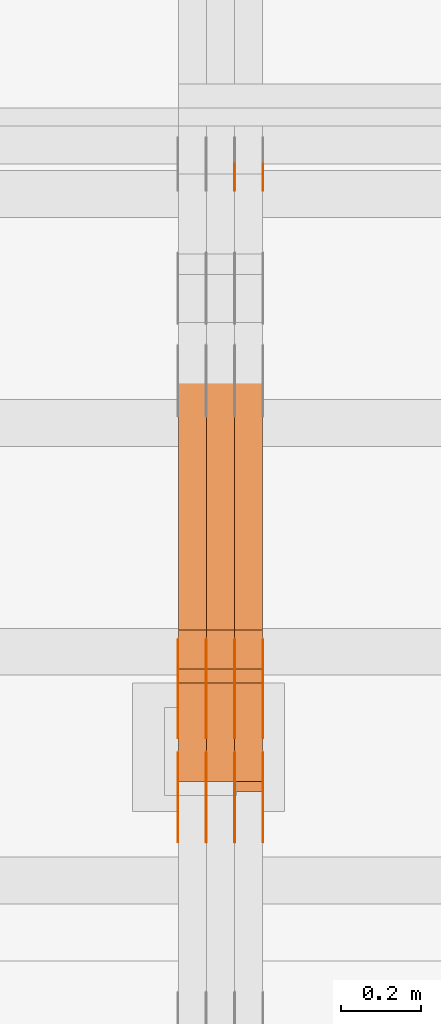
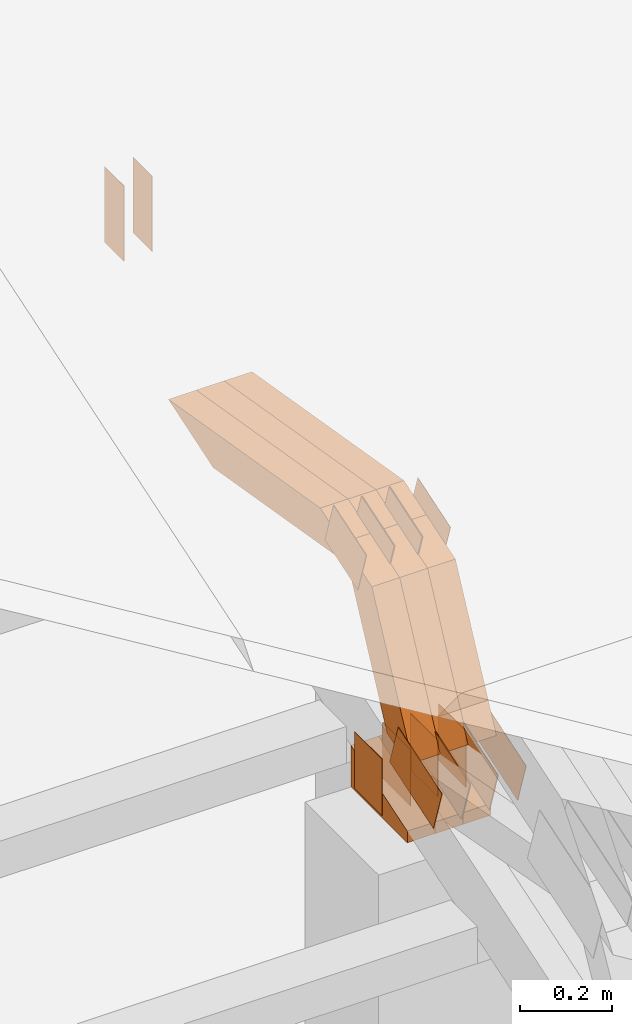
# One storey, part 91 of 385: 29 proxies.
"""IFC2X3 building model written with IfcOpenShell, lengths in millimetres."""

from ifc_helpers import new_model, entity, si_unit, converted_unit, derived_unit, direction, frame, frame_2d, origin, place, context, subcontext, project, spatial, polyline, rectangle, outline, extrude, source, transform, mapped, material, type_object, type_shapes, element, save


model = new_model("IFC2X3")

# Units and contexts
model_context = context("Model", 3, precision=0.01, world=origin(), true_north=direction((6.12303176911189e-17, 1.0)))
body_context = subcontext(model_context, "Body", "Model", "MODEL_VIEW")
ifc_project = project(units=[si_unit("LENGTHUNIT", "METRE", prefix="MILLI"), si_unit("AREAUNIT", "SQUARE_METRE"), si_unit("VOLUMEUNIT", "CUBIC_METRE"), converted_unit("PLANEANGLEUNIT", "DEGREE", entity("IfcRatioMeasure", 0.0174532925199433), si_unit("PLANEANGLEUNIT", "RADIAN"), dimensions=[0, 0, 0, 0, 0, 0, 0]), si_unit("MASSUNIT", "GRAM", prefix="KILO"), derived_unit("MASSDENSITYUNIT", [(si_unit("MASSUNIT", "GRAM", prefix="KILO"), 1), (si_unit("LENGTHUNIT", "METRE"), -3)]), si_unit("TIMEUNIT", "SECOND"), si_unit("FREQUENCYUNIT", "HERTZ"), si_unit("THERMODYNAMICTEMPERATUREUNIT", "DEGREE_CELSIUS"), derived_unit("THERMALTRANSMITTANCEUNIT", [(si_unit("MASSUNIT", "GRAM", prefix="KILO"), 1), (si_unit("THERMODYNAMICTEMPERATUREUNIT", "KELVIN"), -1), (si_unit("TIMEUNIT", "SECOND"), -3)]), derived_unit("VOLUMETRICFLOWRATEUNIT", [(si_unit("LENGTHUNIT", "METRE"), 3), (si_unit("TIMEUNIT", "SECOND"), -1)]), si_unit("ELECTRICCURRENTUNIT", "AMPERE"), si_unit("ELECTRICVOLTAGEUNIT", "VOLT"), si_unit("POWERUNIT", "WATT"), si_unit("FORCEUNIT", "NEWTON", prefix="KILO"), si_unit("ILLUMINANCEUNIT", "LUX"), si_unit("LUMINOUSFLUXUNIT", "LUMEN"), si_unit("LUMINOUSINTENSITYUNIT", "CANDELA"), derived_unit("USERDEFINED", [(si_unit("MASSUNIT", "GRAM", prefix="KILO"), -1), (si_unit("LENGTHUNIT", "METRE"), -2), (si_unit("TIMEUNIT", "SECOND"), 3), (si_unit("LUMINOUSFLUXUNIT", "LUMEN"), 1)]), derived_unit("LINEARVELOCITYUNIT", [(si_unit("LENGTHUNIT", "METRE"), 1), (si_unit("TIMEUNIT", "SECOND"), -1)]), si_unit("PRESSUREUNIT", "PASCAL"), derived_unit("USERDEFINED", [(si_unit("LENGTHUNIT", "METRE"), -2), (si_unit("MASSUNIT", "GRAM", prefix="KILO"), 1), (si_unit("TIMEUNIT", "SECOND"), -2)])], contexts=[model_context])

# Site, building, storey
site_placement = place(None, origin())
site = spatial("IfcSite", under=ifc_project, at=site_placement, CompositionType="ELEMENT")
building_placement = place(site_placement, origin())
building = spatial("IfcBuilding", under=site, at=building_placement, CompositionType="ELEMENT")
storey_placement = place(building_placement, origin())
storey = spatial("IfcBuildingStorey", under=building, at=storey_placement, Name="Default", CompositionType="ELEMENT", Elevation=0.0)

# Proxies
ifc_material_1 = material(Name="IfcSurfaceStyle #140276")
building_element_proxy_type_1 = type_object("IfcBuildingElementProxyType", PredefinedType="NOTDEFINED", material=ifc_material_1)
shared_shape_1 = source(origin(), body_context, "Body", "SweptSolid", [
    extrude(rectangle(XDim=200.0, YDim=84.0, at=frame_2d((0.0, -7.105427357601e-15), x_axis=(1.0, 0.0))), frame((100.0, 42.0, 0.0), z_axis=(0.0, 0.0, 1.0), x_axis=(-1.0, 0.0, 0.0)), (0.0, 0.0, 1.0), 1.3),
])
type_shapes(building_element_proxy_type_1, [shared_shape_1])
proxy_1_placement = place(building_placement, frame((9386.29999999998, 13702.0, 3651.4150390625), z_axis=(-1.0, 0.0, 0.0), x_axis=(0.0, 0.0, -1.0)))
element("IfcBuildingElementProxy", 1, at=proxy_1_placement, inside=storey, type_object=building_element_proxy_type_1, material=ifc_material_1, context=body_context, shape_type="MappedRepresentation", body=[
    mapped(shared_shape_1, transform((0.0, 0.0, 0.0), scale=1.0)),
])
ifc_material_2 = material(Name="IfcSurfaceStyle #140219")
building_element_proxy_type_2 = type_object("IfcBuildingElementProxyType", PredefinedType="NOTDEFINED", material=ifc_material_2)
shared_shape_2 = source(origin(), body_context, "Body", "SweptSolid", [
    extrude(rectangle(XDim=200.0, YDim=84.0, at=frame_2d((0.0, -7.105427357601e-15), x_axis=(1.0, 0.0))), frame((100.0, 42.0, 0.0), z_axis=(0.0, 0.0, 1.0), x_axis=(-1.0, 0.0, 0.0)), (0.0, 0.0, 1.0), 1.3),
])
type_shapes(building_element_proxy_type_2, [shared_shape_2])
proxy_2_placement = place(building_placement, frame((9315.0, 13702.0, 3651.4150390625), z_axis=(-1.0, 0.0, 0.0), x_axis=(0.0, 0.0, -1.0)))
element("IfcBuildingElementProxy", 2, at=proxy_2_placement, inside=storey, type_object=building_element_proxy_type_2, material=ifc_material_2, context=body_context, shape_type="MappedRepresentation", body=[
    mapped(shared_shape_2, transform((0.0, 0.0, 0.0), scale=1.0)),
])
ifc_material_3 = material(Name="IfcSurfaceStyle #138224")
building_element_proxy_type_3 = type_object("IfcBuildingElementProxyType", PredefinedType="NOTDEFINED", material=ifc_material_3)
shared_shape_3 = source(origin(), body_context, "Body", "SweptSolid", [
    extrude(outline(polyline([(-99.9997874178038, -60.0000528641967), (99.9998102700997, -60.0000528641967), (99.9998251396068, 60.0000528641967), (-99.9998479919027, 60.0000528641967), (-99.9997874178038, -60.0000528641967)])), frame((99.9999918898597, 60.0000528641967, 0.0), z_axis=(0.0, 0.0, 1.0), x_axis=(-1.0, 0.0, 0.0)), (0.0, 0.0, 1.0), 1.3),
])
type_shapes(building_element_proxy_type_3, [shared_shape_3])
proxy_3_placement = place(building_placement, frame((9386.29999999998, 11991.9568177725, 3072.52282247925), z_axis=(-1.0, 0.0, 0.0), x_axis=(0.0, 0.951056516295124, 0.309016994375039)))
element("IfcBuildingElementProxy", 3, at=proxy_3_placement, inside=storey, type_object=building_element_proxy_type_3, material=ifc_material_3, context=body_context, shape_type="MappedRepresentation", body=[
    mapped(shared_shape_3, transform((0.0, 0.0, 0.0), scale=1.0)),
])
ifc_material_4 = material(Name="IfcSurfaceStyle #138167")
building_element_proxy_type_4 = type_object("IfcBuildingElementProxyType", PredefinedType="NOTDEFINED", material=ifc_material_4)
shared_shape_4 = source(origin(), body_context, "Body", "SweptSolid", [
    extrude(outline(polyline([(-99.9997874178038, -60.0000528641967), (99.9998102700997, -60.0000528641967), (99.9998251396068, 60.0000528641967), (-99.9998479919027, 60.0000528641967), (-99.9997874178038, -60.0000528641967)])), frame((99.9999918898597, 60.0000528641967, 0.0), z_axis=(0.0, 0.0, 1.0), x_axis=(-1.0, 0.0, 0.0)), (0.0, 0.0, 1.0), 1.3),
])
type_shapes(building_element_proxy_type_4, [shared_shape_4])
proxy_4_placement = place(building_placement, frame((9315.0, 11991.9568177725, 3072.52282247925), z_axis=(-1.0, 0.0, 0.0), x_axis=(0.0, 0.951056516295124, 0.309016994375039)))
element("IfcBuildingElementProxy", 4, at=proxy_4_placement, inside=storey, type_object=building_element_proxy_type_4, material=ifc_material_4, context=body_context, shape_type="MappedRepresentation", body=[
    mapped(shared_shape_4, transform((0.0, 0.0, 0.0), scale=1.0)),
])
ifc_material_5 = material(Name="IfcSurfaceStyle #138110")
building_element_proxy_type_5 = type_object("IfcBuildingElementProxyType", PredefinedType="NOTDEFINED", material=ifc_material_5)
shared_shape_5 = source(origin(), body_context, "Body", "SweptSolid", [
    extrude(outline(polyline([(-99.9997874178038, -60.0000528641967), (99.9998102700997, -60.0000528641967), (99.9998251396068, 60.0000528641967), (-99.9998479919027, 60.0000528641967), (-99.9997874178038, -60.0000528641967)])), frame((99.9999918898597, 60.0000528641967, 0.0), z_axis=(0.0, 0.0, 1.0), x_axis=(-1.0, 0.0, 0.0)), (0.0, 0.0, 1.0), 1.3),
])
type_shapes(building_element_proxy_type_5, [shared_shape_5])
proxy_5_placement = place(building_placement, frame((9316.29999999998, 11991.9568177725, 3072.52282247925), z_axis=(-1.0, 0.0, 0.0), x_axis=(0.0, 0.951056516295124, 0.309016994375039)))
element("IfcBuildingElementProxy", 5, at=proxy_5_placement, inside=storey, type_object=building_element_proxy_type_5, material=ifc_material_5, context=body_context, shape_type="MappedRepresentation", body=[
    mapped(shared_shape_5, transform((0.0, 0.0, 0.0), scale=1.0)),
])
ifc_material_6 = material(Name="IfcSurfaceStyle #138053")
building_element_proxy_type_6 = type_object("IfcBuildingElementProxyType", PredefinedType="NOTDEFINED", material=ifc_material_6)
shared_shape_6 = source(origin(), body_context, "Body", "SweptSolid", [
    extrude(outline(polyline([(-99.9997874178038, -60.0000528641967), (99.9998102700997, -60.0000528641967), (99.9998251396068, 60.0000528641967), (-99.9998479919027, 60.0000528641967), (-99.9997874178038, -60.0000528641967)])), frame((99.9999918898597, 60.0000528641967, 0.0), z_axis=(0.0, 0.0, 1.0), x_axis=(-1.0, 0.0, 0.0)), (0.0, 0.0, 1.0), 1.29999999999998),
])
type_shapes(building_element_proxy_type_6, [shared_shape_6])
proxy_6_placement = place(building_placement, frame((9245.0, 11991.9568177725, 3072.52282247925), z_axis=(-1.0, 0.0, 0.0), x_axis=(0.0, 0.951056516295124, 0.309016994375039)))
element("IfcBuildingElementProxy", 6, at=proxy_6_placement, inside=storey, type_object=building_element_proxy_type_6, material=ifc_material_6, context=body_context, shape_type="MappedRepresentation", body=[
    mapped(shared_shape_6, transform((0.0, 0.0, 0.0), scale=1.0)),
])
ifc_material_7 = material(Name="IfcSurfaceStyle #137996")
building_element_proxy_type_7 = type_object("IfcBuildingElementProxyType", PredefinedType="NOTDEFINED", material=ifc_material_7)
shared_shape_7 = source(origin(), body_context, "Body", "SweptSolid", [
    extrude(outline(polyline([(-99.9997874178038, -60.0000528641967), (99.9998102700997, -60.0000528641967), (99.9998251396068, 60.0000528641967), (-99.9998479919027, 60.0000528641967), (-99.9997874178038, -60.0000528641967)])), frame((99.9999918898597, 60.0000528641967, 0.0), z_axis=(0.0, 0.0, 1.0), x_axis=(-1.0, 0.0, 0.0)), (0.0, 0.0, 1.0), 1.29999999999998),
])
type_shapes(building_element_proxy_type_7, [shared_shape_7])
proxy_7_placement = place(building_placement, frame((9246.29999999998, 11991.9568177725, 3072.52282247925), z_axis=(-1.0, 0.0, 0.0), x_axis=(0.0, 0.951056516295124, 0.309016994375039)))
element("IfcBuildingElementProxy", 7, at=proxy_7_placement, inside=storey, type_object=building_element_proxy_type_7, material=ifc_material_7, context=body_context, shape_type="MappedRepresentation", body=[
    mapped(shared_shape_7, transform((0.0, 0.0, 0.0), scale=1.0)),
])
ifc_material_8 = material(Name="IfcSurfaceStyle #137939")
building_element_proxy_type_8 = type_object("IfcBuildingElementProxyType", PredefinedType="NOTDEFINED", material=ifc_material_8)
shared_shape_8 = source(origin(), body_context, "Body", "SweptSolid", [
    extrude(outline(polyline([(-99.9997874178038, -60.0000528641967), (99.9998102700997, -60.0000528641967), (99.9998251396068, 60.0000528641967), (-99.9998479919027, 60.0000528641967), (-99.9997874178038, -60.0000528641967)])), frame((99.9999918898597, 60.0000528641967, 0.0), z_axis=(0.0, 0.0, 1.0), x_axis=(-1.0, 0.0, 0.0)), (0.0, 0.0, 1.0), 1.29999999999999),
])
type_shapes(building_element_proxy_type_8, [shared_shape_8])
proxy_8_placement = place(building_placement, frame((9175.0, 11991.9568177725, 3072.52282247925), z_axis=(-1.0, 0.0, 0.0), x_axis=(0.0, 0.951056516295124, 0.309016994375039)))
element("IfcBuildingElementProxy", 8, at=proxy_8_placement, inside=storey, type_object=building_element_proxy_type_8, material=ifc_material_8, context=body_context, shape_type="MappedRepresentation", body=[
    mapped(shared_shape_8, transform((0.0, 0.0, 0.0), scale=1.0)),
])
ifc_material_9 = material(Name="IfcSurfaceStyle #137882")
building_element_proxy_type_9 = type_object("IfcBuildingElementProxyType", PredefinedType="NOTDEFINED", material=ifc_material_9)
shared_shape_9 = source(origin(), body_context, "Body", "SweptSolid", [
    extrude(rectangle(XDim=150.0, YDim=119.999999999985, at=frame_2d((-7.105427357601e-15, 0.0), x_axis=(1.0, 0.0))), frame((75.0, 60.0, 0.0), z_axis=(0.0, 0.0, 1.0), x_axis=(-1.0, 0.0, 0.0)), (0.0, 0.0, 1.0), 1.3),
])
type_shapes(building_element_proxy_type_9, [shared_shape_9])
proxy_9_placement = place(building_placement, frame((9386.29999999998, 12372.95703125, 3007.04687500001), z_axis=(-1.0, 0.0, 0.0), x_axis=(0.0, 0.0, -1.0)))
element("IfcBuildingElementProxy", 9, at=proxy_9_placement, inside=storey, type_object=building_element_proxy_type_9, material=ifc_material_9, context=body_context, shape_type="MappedRepresentation", body=[
    mapped(shared_shape_9, transform((0.0, 0.0, 0.0), scale=1.0)),
])
ifc_material_10 = material(Name="IfcSurfaceStyle #137825")
building_element_proxy_type_10 = type_object("IfcBuildingElementProxyType", PredefinedType="NOTDEFINED", material=ifc_material_10)
shared_shape_10 = source(origin(), body_context, "Body", "SweptSolid", [
    extrude(rectangle(XDim=150.0, YDim=119.999999999985, at=frame_2d((-7.105427357601e-15, 0.0), x_axis=(1.0, 0.0))), frame((75.0, 60.0, 0.0), z_axis=(0.0, 0.0, 1.0), x_axis=(-1.0, 0.0, 0.0)), (0.0, 0.0, 1.0), 1.3),
])
type_shapes(building_element_proxy_type_10, [shared_shape_10])
proxy_10_placement = place(building_placement, frame((9315.0, 12372.95703125, 3007.04687500001), z_axis=(-1.0, 0.0, 0.0), x_axis=(0.0, 0.0, -1.0)))
element("IfcBuildingElementProxy", 10, at=proxy_10_placement, inside=storey, type_object=building_element_proxy_type_10, material=ifc_material_10, context=body_context, shape_type="MappedRepresentation", body=[
    mapped(shared_shape_10, transform((0.0, 0.0, 0.0), scale=1.0)),
])
ifc_material_11 = material(Name="IfcSurfaceStyle #137768")
building_element_proxy_type_11 = type_object("IfcBuildingElementProxyType", PredefinedType="NOTDEFINED", material=ifc_material_11)
shared_shape_11 = source(origin(), body_context, "Body", "SweptSolid", [
    extrude(rectangle(XDim=150.0, YDim=119.999999999985, at=frame_2d((-7.105427357601e-15, 0.0), x_axis=(1.0, 0.0))), frame((75.0, 60.0, 0.0), z_axis=(0.0, 0.0, 1.0), x_axis=(-1.0, 0.0, 0.0)), (0.0, 0.0, 1.0), 1.3),
])
type_shapes(building_element_proxy_type_11, [shared_shape_11])
proxy_11_placement = place(building_placement, frame((9316.29999999998, 12372.95703125, 3007.04687500001), z_axis=(-1.0, 0.0, 0.0), x_axis=(0.0, 0.0, -1.0)))
element("IfcBuildingElementProxy", 11, at=proxy_11_placement, inside=storey, type_object=building_element_proxy_type_11, material=ifc_material_11, context=body_context, shape_type="MappedRepresentation", body=[
    mapped(shared_shape_11, transform((0.0, 0.0, 0.0), scale=1.0)),
])
ifc_material_12 = material(Name="IfcSurfaceStyle #137711")
building_element_proxy_type_12 = type_object("IfcBuildingElementProxyType", PredefinedType="NOTDEFINED", material=ifc_material_12)
shared_shape_12 = source(origin(), body_context, "Body", "SweptSolid", [
    extrude(rectangle(XDim=150.0, YDim=119.999999999985, at=frame_2d((-7.105427357601e-15, 0.0), x_axis=(1.0, 0.0))), frame((75.0, 60.0, 0.0), z_axis=(0.0, 0.0, 1.0), x_axis=(-1.0, 0.0, 0.0)), (0.0, 0.0, 1.0), 1.29999999999999),
])
type_shapes(building_element_proxy_type_12, [shared_shape_12])
proxy_12_placement = place(building_placement, frame((9245.0, 12372.95703125, 3007.04687500001), z_axis=(-1.0, 0.0, 0.0), x_axis=(0.0, 0.0, -1.0)))
element("IfcBuildingElementProxy", 12, at=proxy_12_placement, inside=storey, type_object=building_element_proxy_type_12, material=ifc_material_12, context=body_context, shape_type="MappedRepresentation", body=[
    mapped(shared_shape_12, transform((0.0, 0.0, 0.0), scale=1.0)),
])
ifc_material_13 = material(Name="IfcSurfaceStyle #137654")
building_element_proxy_type_13 = type_object("IfcBuildingElementProxyType", PredefinedType="NOTDEFINED", material=ifc_material_13)
shared_shape_13 = source(origin(), body_context, "Body", "SweptSolid", [
    extrude(rectangle(XDim=150.0, YDim=119.999999999985, at=frame_2d((-7.105427357601e-15, 0.0), x_axis=(1.0, 0.0))), frame((75.0, 60.0, 0.0), z_axis=(0.0, 0.0, 1.0), x_axis=(-1.0, 0.0, 0.0)), (0.0, 0.0, 1.0), 1.29999999999999),
])
type_shapes(building_element_proxy_type_13, [shared_shape_13])
proxy_13_placement = place(building_placement, frame((9246.29999999998, 12372.95703125, 3007.04687500001), z_axis=(-1.0, 0.0, 0.0), x_axis=(0.0, 0.0, -1.0)))
element("IfcBuildingElementProxy", 13, at=proxy_13_placement, inside=storey, type_object=building_element_proxy_type_13, material=ifc_material_13, context=body_context, shape_type="MappedRepresentation", body=[
    mapped(shared_shape_13, transform((0.0, 0.0, 0.0), scale=1.0)),
])
ifc_material_14 = material(Name="IfcSurfaceStyle #137597")
building_element_proxy_type_14 = type_object("IfcBuildingElementProxyType", PredefinedType="NOTDEFINED", material=ifc_material_14)
shared_shape_14 = source(origin(), body_context, "Body", "SweptSolid", [
    extrude(rectangle(XDim=150.0, YDim=119.999999999985, at=frame_2d((-7.105427357601e-15, 0.0), x_axis=(1.0, 0.0))), frame((75.0, 60.0, 0.0), z_axis=(0.0, 0.0, 1.0), x_axis=(-1.0, 0.0, 0.0)), (0.0, 0.0, 1.0), 1.29999999999999),
])
type_shapes(building_element_proxy_type_14, [shared_shape_14])
proxy_14_placement = place(building_placement, frame((9175.0, 12372.95703125, 3007.04687500001), z_axis=(-1.0, 0.0, 0.0), x_axis=(0.0, 0.0, -1.0)))
element("IfcBuildingElementProxy", 14, at=proxy_14_placement, inside=storey, type_object=building_element_proxy_type_14, material=ifc_material_14, context=body_context, shape_type="MappedRepresentation", body=[
    mapped(shared_shape_14, transform((0.0, 0.0, 0.0), scale=1.0)),
])
ifc_material_15 = material(Name="IfcSurfaceStyle #130700")
building_element_proxy_type_15 = type_object("IfcBuildingElementProxyType", PredefinedType="NOTDEFINED", material=ifc_material_15)
shared_shape_15 = source(origin(), body_context, "Body", "SweptSolid", [
    extrude(outline(polyline([(-74.9998754286244, -60.0000016373506), (74.9998605591063, -60.0000016373506), (74.9998754286244, 60.0000016373506), (-74.9998605591063, 60.0000016373506), (-74.9998754286244, -60.0000016373506)])), frame((74.9998754286244, 60.0000016373506, 0.0), z_axis=(0.0, 0.0, 1.0), x_axis=(-1.0, 0.0, 0.0)), (0.0, 0.0, 1.0), 1.3),
])
type_shapes(building_element_proxy_type_15, [shared_shape_15])
proxy_15_placement = place(building_placement, frame((9386.29999999998, 12321.1620861463, 3506.17707344366), z_axis=(-1.0, 0.0, 0.0), x_axis=(0.0, 0.951056516295154, 0.309016994374948)))
element("IfcBuildingElementProxy", 15, at=proxy_15_placement, inside=storey, type_object=building_element_proxy_type_15, material=ifc_material_15, context=body_context, shape_type="MappedRepresentation", body=[
    mapped(shared_shape_15, transform((0.0, 0.0, 0.0), scale=1.0)),
])
ifc_material_16 = material(Name="IfcSurfaceStyle #130643")
building_element_proxy_type_16 = type_object("IfcBuildingElementProxyType", PredefinedType="NOTDEFINED", material=ifc_material_16)
shared_shape_16 = source(origin(), body_context, "Body", "SweptSolid", [
    extrude(outline(polyline([(-74.9998754286244, -60.0000016373506), (74.9998605591063, -60.0000016373506), (74.9998754286244, 60.0000016373506), (-74.9998605591063, 60.0000016373506), (-74.9998754286244, -60.0000016373506)])), frame((74.9998754286244, 60.0000016373506, 0.0), z_axis=(0.0, 0.0, 1.0), x_axis=(-1.0, 0.0, 0.0)), (0.0, 0.0, 1.0), 1.3),
])
type_shapes(building_element_proxy_type_16, [shared_shape_16])
proxy_16_placement = place(building_placement, frame((9315.0, 12321.1620861463, 3506.17707344366), z_axis=(-1.0, 0.0, 0.0), x_axis=(0.0, 0.951056516295154, 0.309016994374948)))
element("IfcBuildingElementProxy", 16, at=proxy_16_placement, inside=storey, type_object=building_element_proxy_type_16, material=ifc_material_16, context=body_context, shape_type="MappedRepresentation", body=[
    mapped(shared_shape_16, transform((0.0, 0.0, 0.0), scale=1.0)),
])
ifc_material_17 = material(Name="IfcSurfaceStyle #130586")
building_element_proxy_type_17 = type_object("IfcBuildingElementProxyType", PredefinedType="NOTDEFINED", material=ifc_material_17)
shared_shape_17 = source(origin(), body_context, "Body", "SweptSolid", [
    extrude(outline(polyline([(-74.9998754286244, -60.0000016373506), (74.9998605591063, -60.0000016373506), (74.9998754286244, 60.0000016373506), (-74.9998605591063, 60.0000016373506), (-74.9998754286244, -60.0000016373506)])), frame((74.9998754286244, 60.0000016373506, 0.0), z_axis=(0.0, 0.0, 1.0), x_axis=(-1.0, 0.0, 0.0)), (0.0, 0.0, 1.0), 1.3),
])
type_shapes(building_element_proxy_type_17, [shared_shape_17])
proxy_17_placement = place(building_placement, frame((9316.29999999998, 12321.1620861463, 3506.17707344366), z_axis=(-1.0, 0.0, 0.0), x_axis=(0.0, 0.951056516295154, 0.309016994374948)))
element("IfcBuildingElementProxy", 17, at=proxy_17_placement, inside=storey, type_object=building_element_proxy_type_17, material=ifc_material_17, context=body_context, shape_type="MappedRepresentation", body=[
    mapped(shared_shape_17, transform((0.0, 0.0, 0.0), scale=1.0)),
])
ifc_material_18 = material(Name="IfcSurfaceStyle #130529")
building_element_proxy_type_18 = type_object("IfcBuildingElementProxyType", PredefinedType="NOTDEFINED", material=ifc_material_18)
shared_shape_18 = source(origin(), body_context, "Body", "SweptSolid", [
    extrude(outline(polyline([(-74.9998754286244, -60.0000016373506), (74.9998605591063, -60.0000016373506), (74.9998754286244, 60.0000016373506), (-74.9998605591063, 60.0000016373506), (-74.9998754286244, -60.0000016373506)])), frame((74.9998754286244, 60.0000016373506, 0.0), z_axis=(0.0, 0.0, 1.0), x_axis=(-1.0, 0.0, 0.0)), (0.0, 0.0, 1.0), 1.29999999999999),
])
type_shapes(building_element_proxy_type_18, [shared_shape_18])
proxy_18_placement = place(building_placement, frame((9245.0, 12321.1620861463, 3506.17707344366), z_axis=(-1.0, 0.0, 0.0), x_axis=(0.0, 0.951056516295154, 0.309016994374948)))
element("IfcBuildingElementProxy", 18, at=proxy_18_placement, inside=storey, type_object=building_element_proxy_type_18, material=ifc_material_18, context=body_context, shape_type="MappedRepresentation", body=[
    mapped(shared_shape_18, transform((0.0, 0.0, 0.0), scale=1.0)),
])
ifc_material_19 = material(Name="IfcSurfaceStyle #130472")
building_element_proxy_type_19 = type_object("IfcBuildingElementProxyType", PredefinedType="NOTDEFINED", material=ifc_material_19)
shared_shape_19 = source(origin(), body_context, "Body", "SweptSolid", [
    extrude(outline(polyline([(-74.9998754286244, -60.0000016373506), (74.9998605591063, -60.0000016373506), (74.9998754286244, 60.0000016373506), (-74.9998605591063, 60.0000016373506), (-74.9998754286244, -60.0000016373506)])), frame((74.9998754286244, 60.0000016373506, 0.0), z_axis=(0.0, 0.0, 1.0), x_axis=(-1.0, 0.0, 0.0)), (0.0, 0.0, 1.0), 1.29999999999999),
])
type_shapes(building_element_proxy_type_19, [shared_shape_19])
proxy_19_placement = place(building_placement, frame((9246.29999999998, 12321.1620861463, 3506.17707344366), z_axis=(-1.0, 0.0, 0.0), x_axis=(0.0, 0.951056516295154, 0.309016994374948)))
element("IfcBuildingElementProxy", 19, at=proxy_19_placement, inside=storey, type_object=building_element_proxy_type_19, material=ifc_material_19, context=body_context, shape_type="MappedRepresentation", body=[
    mapped(shared_shape_19, transform((0.0, 0.0, 0.0), scale=1.0)),
])
ifc_material_20 = material(Name="IfcSurfaceStyle #130415")
building_element_proxy_type_20 = type_object("IfcBuildingElementProxyType", PredefinedType="NOTDEFINED", material=ifc_material_20)
shared_shape_20 = source(origin(), body_context, "Body", "SweptSolid", [
    extrude(outline(polyline([(-74.9998754286244, -60.0000016373506), (74.9998605591063, -60.0000016373506), (74.9998754286244, 60.0000016373506), (-74.9998605591063, 60.0000016373506), (-74.9998754286244, -60.0000016373506)])), frame((74.9998754286244, 60.0000016373506, 0.0), z_axis=(0.0, 0.0, 1.0), x_axis=(-1.0, 0.0, 0.0)), (0.0, 0.0, 1.0), 1.29999999999999),
])
type_shapes(building_element_proxy_type_20, [shared_shape_20])
proxy_20_placement = place(building_placement, frame((9175.0, 12321.1620861463, 3506.17707344366), z_axis=(-1.0, 0.0, 0.0), x_axis=(0.0, 0.951056516295154, 0.309016994374948)))
element("IfcBuildingElementProxy", 20, at=proxy_20_placement, inside=storey, type_object=building_element_proxy_type_20, material=ifc_material_20, context=body_context, shape_type="MappedRepresentation", body=[
    mapped(shared_shape_20, transform((0.0, 0.0, 0.0), scale=1.0)),
])
ifc_material_21 = material(Name="IfcSurfaceStyle #122240")
building_element_proxy_type_21 = type_object("IfcBuildingElementProxyType", Name="T1-E1 122238", PredefinedType="NOTDEFINED", material=ifc_material_21)
shared_shape_21 = source(origin(), body_context, "Body", "SweptSolid", [
    extrude(outline(polyline([(-75.1378173828004, -122.500000000005), (35.3350830078246, -122.500000000005), (35.3350830078004, 122.500000000005), (4.46765136717545, 122.500000000005), (-75.1378173828004, -122.500000000005)])), frame((35.3350830078246, 122.500000104877, 0.0), z_axis=(0.0, 0.0, 1.0), x_axis=(-1.0, 0.0, 0.0)), (0.0, 0.0, 1.0), 70.0),
])
type_shapes(building_element_proxy_type_21, [shared_shape_21])
proxy_21_placement = place(building_placement, frame((9385.0, 12145.0, 2849.54565429685), z_axis=(-1.0, 0.0, 0.0), x_axis=(0.0, 0.0, 1.0)))
element("IfcBuildingElementProxy", 21, at=proxy_21_placement, inside=storey, type_object=building_element_proxy_type_21, material=ifc_material_21, Name="T1-E1", context=body_context, shape_type="MappedRepresentation", body=[
    mapped(shared_shape_21, transform((0.0, 0.0, 0.0), scale=1.0)),
])
ifc_material_22 = material(Name="IfcSurfaceStyle #122183")
building_element_proxy_type_22 = type_object("IfcBuildingElementProxyType", Name="T1-E1 122181", PredefinedType="NOTDEFINED", material=ifc_material_22)
shared_shape_22 = source(origin(), body_context, "Body", "SweptSolid", [
    extrude(outline(polyline([(-75.1378173828004, -122.500000000005), (35.3350830078246, -122.500000000005), (35.3350830078004, 122.500000000005), (4.46765136717545, 122.500000000005), (-75.1378173828004, -122.500000000005)])), frame((35.3350830078246, 122.500000104877, 0.0), z_axis=(0.0, 0.0, 1.0), x_axis=(-1.0, 0.0, 0.0)), (0.0, 0.0, 1.0), 70.0),
])
type_shapes(building_element_proxy_type_22, [shared_shape_22])
proxy_22_placement = place(building_placement, frame((9315.0, 12145.0, 2849.54565429685), z_axis=(-1.0, 0.0, 0.0), x_axis=(0.0, 0.0, 1.0)))
element("IfcBuildingElementProxy", 22, at=proxy_22_placement, inside=storey, type_object=building_element_proxy_type_22, material=ifc_material_22, Name="T1-E1", context=body_context, shape_type="MappedRepresentation", body=[
    mapped(shared_shape_22, transform((0.0, 0.0, 0.0), scale=1.0)),
])
ifc_material_23 = material(Name="IfcSurfaceStyle #122126")
building_element_proxy_type_23 = type_object("IfcBuildingElementProxyType", Name="T1-E1 122124", PredefinedType="NOTDEFINED", material=ifc_material_23)
shared_shape_23 = source(origin(), body_context, "Body", "SweptSolid", [
    extrude(outline(polyline([(-75.1378173828004, -122.500000000005), (35.3350830078246, -122.500000000005), (35.3350830078004, 122.500000000005), (4.46765136717545, 122.500000000005), (-75.1378173828004, -122.500000000005)])), frame((35.3350830078246, 122.500000104877, 0.0), z_axis=(0.0, 0.0, 1.0), x_axis=(-1.0, 0.0, 0.0)), (0.0, 0.0, 1.0), 70.0),
])
type_shapes(building_element_proxy_type_23, [shared_shape_23])
proxy_23_placement = place(building_placement, frame((9245.0, 12145.0, 2849.54565429685), z_axis=(-1.0, 0.0, 0.0), x_axis=(0.0, 0.0, 1.0)))
element("IfcBuildingElementProxy", 23, at=proxy_23_placement, inside=storey, type_object=building_element_proxy_type_23, material=ifc_material_23, Name="T1-E1", context=body_context, shape_type="MappedRepresentation", body=[
    mapped(shared_shape_23, transform((0.0, 0.0, 0.0), scale=1.0)),
])
ifc_material_24 = material(Name="IfcSurfaceStyle #120512")
building_element_proxy_type_24 = type_object("IfcBuildingElementProxyType", Name="T1-W7 120510", PredefinedType="NOTDEFINED", material=ifc_material_24)
shared_shape_24 = source(origin(), body_context, "Body", "SweptSolid", [
    extrude(outline(polyline([(-296.174043820986, -47.5000676566704), (297.841254477443, -47.5000676566704), (283.518570346415, -7.10254316533821e-06), (192.674144473719, 47.500071207942), (-477.859925476591, 47.500071207942), (-296.174043820986, -47.5000676566704)])), frame((297.841254477443, 47.5000816097442, 0.0), z_axis=(0.0, 0.0, 1.0), x_axis=(-1.0, 0.0, 0.0)), (0.0, 0.0, 1.0), 70.0),
])
type_shapes(building_element_proxy_type_24, [shared_shape_24])
proxy_24_placement = place(building_placement, frame((9385.0, 12419.2991208897, 3526.2136755972), z_axis=(-1.0, 0.0, 0.0), x_axis=(0.0, 0.985983815111804, -0.166840991178939)))
element("IfcBuildingElementProxy", 24, at=proxy_24_placement, inside=storey, type_object=building_element_proxy_type_24, material=ifc_material_24, Name="T1-W7", context=body_context, shape_type="MappedRepresentation", body=[
    mapped(shared_shape_24, transform((0.0, 0.0, 0.0), scale=1.0)),
])
ifc_material_25 = material(Name="IfcSurfaceStyle #120446")
building_element_proxy_type_25 = type_object("IfcBuildingElementProxyType", Name="T1-W7 120444", PredefinedType="NOTDEFINED", material=ifc_material_25)
shared_shape_25 = source(origin(), body_context, "Body", "SweptSolid", [
    extrude(outline(polyline([(-296.174043820986, -47.5000676566704), (297.841254477443, -47.5000676566704), (283.518570346415, -7.10254316533821e-06), (192.674144473719, 47.500071207942), (-477.859925476591, 47.500071207942), (-296.174043820986, -47.5000676566704)])), frame((297.841254477443, 47.5000816097442, 0.0), z_axis=(0.0, 0.0, 1.0), x_axis=(-1.0, 0.0, 0.0)), (0.0, 0.0, 1.0), 70.0),
])
type_shapes(building_element_proxy_type_25, [shared_shape_25])
proxy_25_placement = place(building_placement, frame((9315.0, 12419.2991208897, 3526.2136755972), z_axis=(-1.0, 0.0, 0.0), x_axis=(0.0, 0.985983815111804, -0.166840991178939)))
element("IfcBuildingElementProxy", 25, at=proxy_25_placement, inside=storey, type_object=building_element_proxy_type_25, material=ifc_material_25, Name="T1-W7", context=body_context, shape_type="MappedRepresentation", body=[
    mapped(shared_shape_25, transform((0.0, 0.0, 0.0), scale=1.0)),
])
ifc_material_26 = material(Name="IfcSurfaceStyle #120380")
building_element_proxy_type_26 = type_object("IfcBuildingElementProxyType", Name="T1-W7 120378", PredefinedType="NOTDEFINED", material=ifc_material_26)
shared_shape_26 = source(origin(), body_context, "Body", "SweptSolid", [
    extrude(outline(polyline([(-296.174043820986, -47.5000676566704), (297.841254477443, -47.5000676566704), (283.518570346415, -7.10254316533821e-06), (192.674144473719, 47.500071207942), (-477.859925476591, 47.500071207942), (-296.174043820986, -47.5000676566704)])), frame((297.841254477443, 47.5000816097442, 0.0), z_axis=(0.0, 0.0, 1.0), x_axis=(-1.0, 0.0, 0.0)), (0.0, 0.0, 1.0), 70.0),
])
type_shapes(building_element_proxy_type_26, [shared_shape_26])
proxy_26_placement = place(building_placement, frame((9245.0, 12419.2991208897, 3526.2136755972), z_axis=(-1.0, 0.0, 0.0), x_axis=(0.0, 0.985983815111804, -0.166840991178939)))
element("IfcBuildingElementProxy", 26, at=proxy_26_placement, inside=storey, type_object=building_element_proxy_type_26, material=ifc_material_26, Name="T1-W7", context=body_context, shape_type="MappedRepresentation", body=[
    mapped(shared_shape_26, transform((0.0, 0.0, 0.0), scale=1.0)),
])
ifc_material_27 = material(Name="IfcSurfaceStyle #120116")
building_element_proxy_type_27 = type_object("IfcBuildingElementProxyType", Name="T1-W36 120114", PredefinedType="NOTDEFINED", material=ifc_material_27)
shared_shape_27 = source(origin(), body_context, "Body", "SweptSolid", [
    extrude(outline(polyline([(-300.714670922549, -47.4998881108849), (134.031527004269, -47.499888110885), (180.52054953879, -0.000136170977331764), (193.89900152221, 47.500563476126), (-207.736407142719, 47.4993489166213), (-300.714670922549, -47.4998881108849)])), frame((193.899145164686, 47.5001861375837, 0.0), z_axis=(0.0, 0.0, 1.0), x_axis=(-1.0, 3.02403492980632e-06, 0.0)), (0.0, 0.0, 1.0), 70.0),
])
type_shapes(building_element_proxy_type_27, [shared_shape_27])
proxy_27_placement = place(building_placement, frame((9385.0, 12120.5935627532, 3076.1128858536), z_axis=(-1.0, 0.0, 0.0), x_axis=(0.0, 0.444384650266842, 0.895836080210669)))
element("IfcBuildingElementProxy", 27, at=proxy_27_placement, inside=storey, type_object=building_element_proxy_type_27, material=ifc_material_27, Name="T1-W36", context=body_context, shape_type="MappedRepresentation", body=[
    mapped(shared_shape_27, transform((0.0, 0.0, 0.0), scale=1.0)),
])
ifc_material_28 = material(Name="IfcSurfaceStyle #120050")
building_element_proxy_type_28 = type_object("IfcBuildingElementProxyType", Name="T1-W36 120048", PredefinedType="NOTDEFINED", material=ifc_material_28)
shared_shape_28 = source(origin(), body_context, "Body", "SweptSolid", [
    extrude(outline(polyline([(-300.714670922549, -47.4998881108849), (134.031527004269, -47.499888110885), (180.52054953879, -0.000136170977331764), (193.89900152221, 47.500563476126), (-207.736407142719, 47.4993489166213), (-300.714670922549, -47.4998881108849)])), frame((193.899145164686, 47.5001861375837, 0.0), z_axis=(0.0, 0.0, 1.0), x_axis=(-1.0, 3.02403492980632e-06, 0.0)), (0.0, 0.0, 1.0), 70.0),
])
type_shapes(building_element_proxy_type_28, [shared_shape_28])
proxy_28_placement = place(building_placement, frame((9315.0, 12120.5935627532, 3076.1128858536), z_axis=(-1.0, 0.0, 0.0), x_axis=(0.0, 0.444384650266842, 0.895836080210669)))
element("IfcBuildingElementProxy", 28, at=proxy_28_placement, inside=storey, type_object=building_element_proxy_type_28, material=ifc_material_28, Name="T1-W36", context=body_context, shape_type="MappedRepresentation", body=[
    mapped(shared_shape_28, transform((0.0, 0.0, 0.0), scale=1.0)),
])
ifc_material_29 = material(Name="IfcSurfaceStyle #119984")
building_element_proxy_type_29 = type_object("IfcBuildingElementProxyType", Name="T1-W36 119982", PredefinedType="NOTDEFINED", material=ifc_material_29)
shared_shape_29 = source(origin(), body_context, "Body", "SweptSolid", [
    extrude(outline(polyline([(-300.714670922549, -47.4998881108849), (134.031527004269, -47.499888110885), (180.52054953879, -0.000136170977331764), (193.89900152221, 47.500563476126), (-207.736407142719, 47.4993489166213), (-300.714670922549, -47.4998881108849)])), frame((193.899145164686, 47.5001861375837, 0.0), z_axis=(0.0, 0.0, 1.0), x_axis=(-1.0, 3.02403492980632e-06, 0.0)), (0.0, 0.0, 1.0), 70.0),
])
type_shapes(building_element_proxy_type_29, [shared_shape_29])
proxy_29_placement = place(building_placement, frame((9245.0, 12120.5935627532, 3076.1128858536), z_axis=(-1.0, 0.0, 0.0), x_axis=(0.0, 0.444384650266842, 0.895836080210669)))
element("IfcBuildingElementProxy", 29, at=proxy_29_placement, inside=storey, type_object=building_element_proxy_type_29, material=ifc_material_29, Name="T1-W36", context=body_context, shape_type="MappedRepresentation", body=[
    mapped(shared_shape_29, transform((0.0, 0.0, 0.0), scale=1.0)),
])

save(model, "model.ifc")
